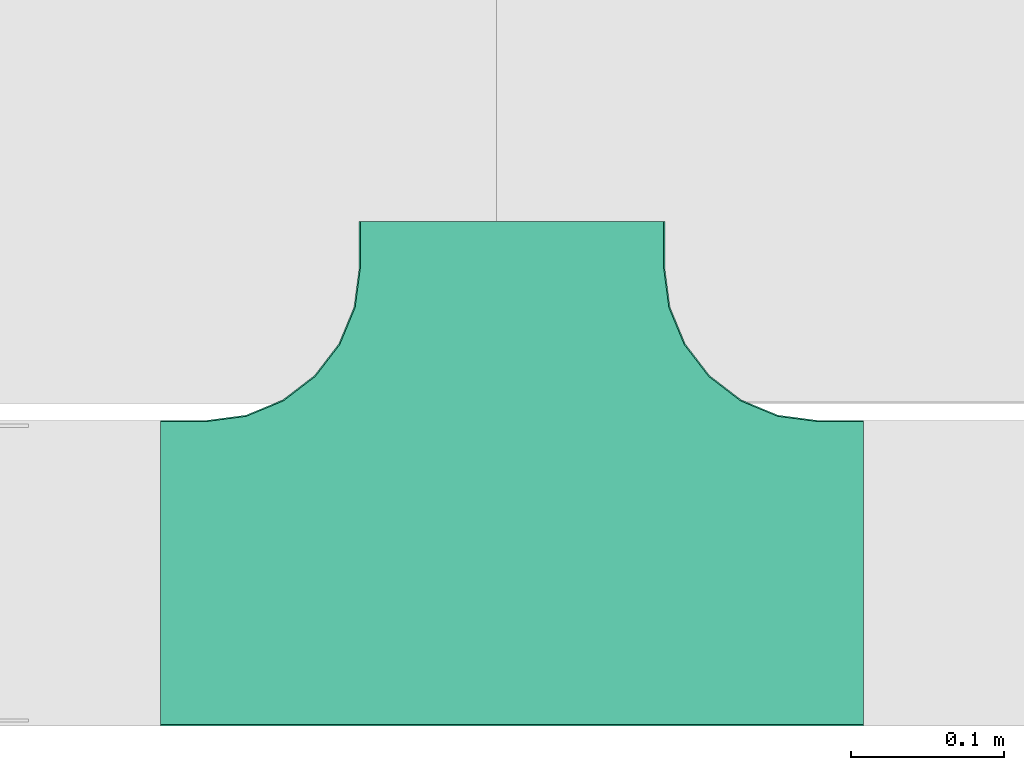
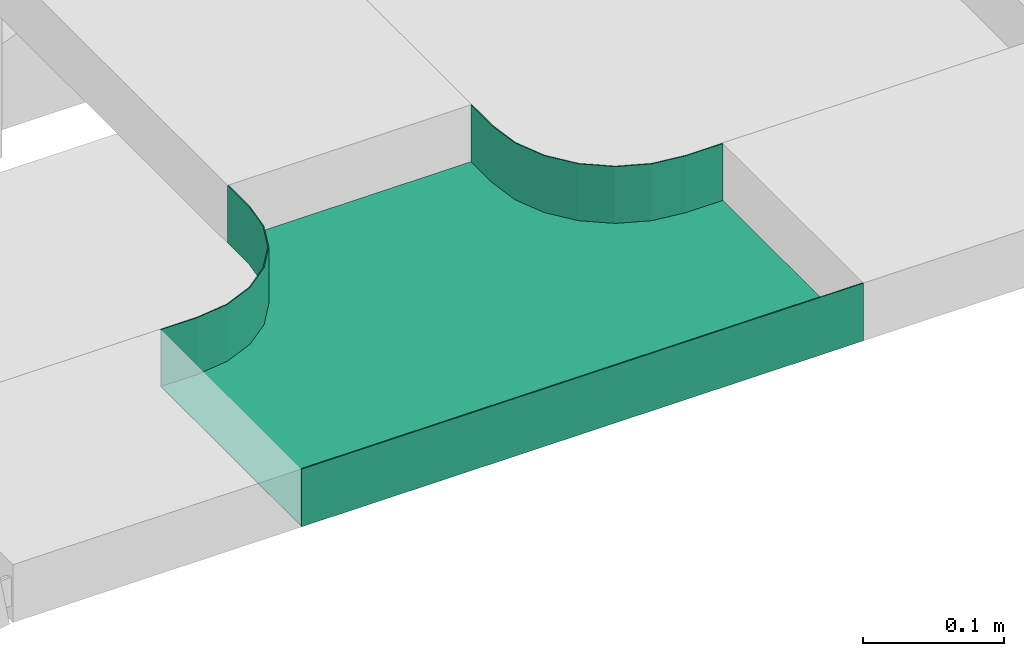
# One storey, part 19 of 19: 1 flow fitting.
"""IFC2X3 building model written with IfcOpenShell, lengths in millimetres."""

from ifc_helpers import new_model, entity, si_unit, converted_unit, derived_unit, direction, frame, origin, place, context, subcontext, project, spatial, faceted_brep, source, transform, mapped, material, type_object, type_shapes, element, save


model = new_model("IFC2X3")

# Units and contexts
model_context = context("Model", 3, precision=0.01, world=origin(), true_north=direction((6.12303176911189e-17, 1.0)))
body_context = subcontext(model_context, "Body", "Model", "MODEL_VIEW")
ifc_project = project(units=[si_unit("LENGTHUNIT", "METRE", prefix="MILLI"), si_unit("AREAUNIT", "SQUARE_METRE"), si_unit("VOLUMEUNIT", "CUBIC_METRE"), converted_unit("PLANEANGLEUNIT", "DEGREE", entity("IfcRatioMeasure", 0.0174532925199433), si_unit("PLANEANGLEUNIT", "RADIAN"), dimensions=[0, 0, 0, 0, 0, 0, 0]), si_unit("MASSUNIT", "GRAM", prefix="KILO"), derived_unit("MASSDENSITYUNIT", [(si_unit("MASSUNIT", "GRAM", prefix="KILO"), 1), (si_unit("LENGTHUNIT", "METRE"), -3)]), derived_unit("MOMENTOFINERTIAUNIT", [(si_unit("LENGTHUNIT", "METRE"), 4)]), si_unit("TIMEUNIT", "SECOND"), si_unit("FREQUENCYUNIT", "HERTZ"), si_unit("THERMODYNAMICTEMPERATUREUNIT", "DEGREE_CELSIUS"), derived_unit("THERMALTRANSMITTANCEUNIT", [(si_unit("MASSUNIT", "GRAM", prefix="KILO"), 1), (si_unit("THERMODYNAMICTEMPERATUREUNIT", "KELVIN"), -1), (si_unit("TIMEUNIT", "SECOND"), -3)]), derived_unit("VOLUMETRICFLOWRATEUNIT", [(si_unit("LENGTHUNIT", "METRE"), 3), (si_unit("TIMEUNIT", "SECOND"), -1)]), derived_unit("MASSFLOWRATEUNIT", [(si_unit("MASSUNIT", "GRAM", prefix="KILO"), 1), (si_unit("TIMEUNIT", "SECOND"), -1)]), derived_unit("ROTATIONALFREQUENCYUNIT", [(si_unit("TIMEUNIT", "SECOND"), -1)]), si_unit("ELECTRICCURRENTUNIT", "AMPERE"), si_unit("ELECTRICVOLTAGEUNIT", "VOLT"), si_unit("POWERUNIT", "WATT"), si_unit("FORCEUNIT", "NEWTON", prefix="KILO"), si_unit("ILLUMINANCEUNIT", "LUX"), si_unit("LUMINOUSFLUXUNIT", "LUMEN"), si_unit("LUMINOUSINTENSITYUNIT", "CANDELA"), derived_unit("USERDEFINED", [(si_unit("MASSUNIT", "GRAM", prefix="KILO"), -1), (si_unit("LENGTHUNIT", "METRE"), -2), (si_unit("TIMEUNIT", "SECOND"), 3), (si_unit("LUMINOUSFLUXUNIT", "LUMEN"), 1)]), derived_unit("LINEARVELOCITYUNIT", [(si_unit("LENGTHUNIT", "METRE"), 1), (si_unit("TIMEUNIT", "SECOND"), -1)]), si_unit("PRESSUREUNIT", "PASCAL"), derived_unit("USERDEFINED", [(si_unit("LENGTHUNIT", "METRE"), -2), (si_unit("MASSUNIT", "GRAM", prefix="KILO"), 1), (si_unit("TIMEUNIT", "SECOND"), -2)]), derived_unit("LINEARFORCEUNIT", [(si_unit("MASSUNIT", "GRAM", prefix="KILO"), 1), (si_unit("LENGTHUNIT", "METRE"), 1), (si_unit("TIMEUNIT", "SECOND"), -2), (si_unit("LENGTHUNIT", "METRE"), -1)]), derived_unit("PLANARFORCEUNIT", [(si_unit("MASSUNIT", "GRAM", prefix="KILO"), 1), (si_unit("LENGTHUNIT", "METRE"), 1), (si_unit("TIMEUNIT", "SECOND"), -2), (si_unit("LENGTHUNIT", "METRE"), -2)])], contexts=[model_context])

# Site, building, storey
site_placement = place(None, origin())
site = spatial("IfcSite", under=ifc_project, at=site_placement, CompositionType="ELEMENT")
building_placement = place(site_placement, origin())
building = spatial("IfcBuilding", under=site, at=building_placement, CompositionType="ELEMENT")
storey_placement = place(building_placement, frame((0.0, 0.0, 12000.0)))
storey = spatial("IfcBuildingStorey", under=building, at=storey_placement, CompositionType="ELEMENT", Elevation=12000.0)

# Flow fitting
ifc_material = material()
cable_carrier_fitting_type = type_object("IfcCableCarrierFittingType", PredefinedType="NOTDEFINED", material=ifc_material)
shared_shape = source(origin(), body_context, "Body", "Brep", [
    faceted_brep([(-112.7, 149.6, 25.0), (-102.63, 173.91, 25.0), (-99.2, 200.0, 25.0), (-99.2, 230.0, 25.0), (-100.0, 230.0, 25.0), (-100.0, 200.0, 25.0), (-103.41, 174.12, 25.0), (-113.4, 150.0, 25.0), (-129.29, 129.29, 25.0), (-150.0, 113.4, 25.0), (-174.12, 103.41, 25.0), (-200.0, 100.0, 25.0), (-230.0, 100.0, 25.0), (-230.0, 99.2, 25.0), (-200.0, 99.2, 25.0), (-173.91, 102.63, 25.0), (-149.6, 112.7, 25.0), (-128.72, 128.72, 25.0), (200.0, 99.2, 25.0), (230.0, 99.2, 25.0), (230.0, 100.0, 25.0), (200.0, 100.0, 25.0), (174.12, 103.41, 25.0), (150.0, 113.4, 25.0), (129.29, 129.29, 25.0), (113.4, 150.0, 25.0), (103.41, 174.12, 25.0), (100.0, 200.0, 25.0), (100.0, 230.0, 25.0), (99.2, 230.0, 25.0), (99.2, 200.0, 25.0), (102.63, 173.91, 25.0), (112.7, 149.6, 25.0), (128.72, 128.72, 25.0), (149.6, 112.7, 25.0), (173.91, 102.63, 25.0), (-230.0, -99.2, 25.0), (-230.0, -100.0, 25.0), (230.0, -100.0, 25.0), (230.0, -99.2, 25.0), (-200.0, 100.0, -25.0), (-174.12, 103.41, -25.0), (-150.0, 113.4, -25.0), (-129.29, 129.29, -25.0), (-113.4, 150.0, -25.0), (-103.41, 174.12, -25.0), (-100.0, 200.0, -25.0), (-100.0, 230.0, -25.0), (100.0, 230.0, -25.0), (100.0, 200.0, -25.0), (103.41, 174.12, -25.0), (113.4, 150.0, -25.0), (129.29, 129.29, -25.0), (150.0, 113.4, -25.0), (174.12, 103.41, -25.0), (200.0, 100.0, -25.0), (230.0, 100.0, -25.0), (230.0, -100.0, -25.0), (-230.0, -100.0, -25.0), (-230.0, 100.0, -25.0), (-100.0, 200.0, -24.2), (-99.2, 230.0, -24.2), (99.2, 230.0, -24.2), (-99.2, 200.0, -24.2), (-230.0, 99.2, -24.2), (-200.0, 99.2, -24.2), (200.0, 99.2, -24.2), (230.0, 99.2, -24.2), (-230.0, -99.2, -24.2), (-200.0, 100.0, -24.2), (200.0, 100.0, -24.2), (230.0, -99.2, -24.2), (99.2, 200.0, -24.2), (100.0, 200.0, -24.2), (-173.91, 102.63, -24.2), (173.91, 102.63, -24.2), (149.6, 112.7, -24.2), (128.72, 128.72, -24.2), (112.7, 149.6, -24.2), (102.63, 173.91, -24.2), (-102.63, 173.91, -24.2), (-112.7, 149.6, -24.2), (-128.72, 128.72, -24.2), (-149.6, 112.7, -24.2)], [[[0, 1, 2, 3, 4, 5, 6, 7, 8, 9, 10, 11, 12, 13, 14, 15, 16, 17]], [[18, 19, 20, 21, 22, 23, 24, 25, 26, 27, 28, 29, 30, 31, 32, 33, 34, 35]], [[36, 37, 38, 39]], [[40, 41, 42, 43, 44, 45, 46, 47, 48, 49, 50, 51, 52, 53, 54, 55, 56, 57, 58, 59]], [[60, 5, 4, 47, 46]], [[61, 62, 29, 28, 48, 47, 4, 3]], [[61, 3, 2, 63]], [[64, 65, 14, 13]], [[66, 67, 19, 18]], [[68, 64, 13, 12, 59, 58, 37, 36]], [[69, 40, 59, 12, 11]], [[70, 21, 20, 56, 55]], [[67, 71, 39, 38, 57, 56, 20, 19]], [[62, 72, 30, 29]], [[73, 49, 48, 28, 27]], [[57, 38, 37, 58]], [[68, 36, 39, 71]], [[74, 65, 64, 68, 71, 67, 66, 75, 76, 77, 78, 79, 72, 62, 61, 63, 80, 81, 82, 83]], [[69, 11, 10, 41, 40]], [[10, 9, 42, 41]], [[8, 43, 42, 9]], [[44, 7, 6, 45]], [[5, 60, 46, 45, 6]], [[43, 8, 7, 44]], [[80, 63, 2, 1]], [[81, 80, 1, 0]], [[81, 0, 17, 82]], [[83, 82, 17, 16]], [[74, 83, 16, 15]], [[74, 15, 14, 65]], [[75, 66, 18, 35]], [[76, 75, 35, 34]], [[76, 34, 33, 77]], [[32, 78, 77, 33]], [[31, 79, 78, 32]], [[31, 30, 72, 79]], [[73, 27, 26, 50, 49]], [[51, 50, 26, 25]], [[52, 51, 25, 24]], [[53, 52, 24, 23]], [[23, 22, 54, 53]], [[21, 70, 55, 54, 22]]]),
])
type_shapes(cable_carrier_fitting_type, [shared_shape])
flow_fitting_placement = place(storey_placement, frame((60192.55, 8713.82, 2895.0)))
element("IfcFlowFitting", 1, at=flow_fitting_placement, inside=storey, type_object=cable_carrier_fitting_type, material=ifc_material, Name="470_DKC_S5_T", context=body_context, shape_type="MappedRepresentation", body=[
    mapped(shared_shape, transform((0.0, 0.0, 0.0), scale=1.0)),
])

save(model, "model.ifc")
